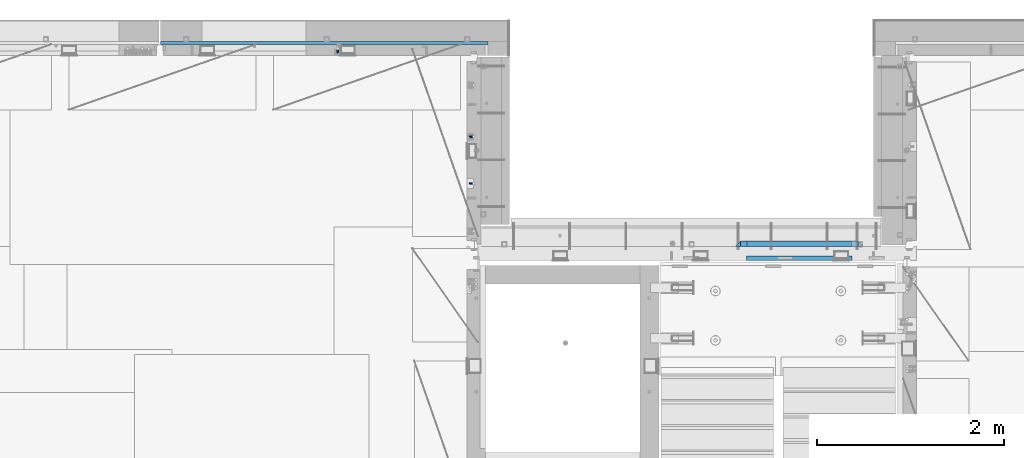
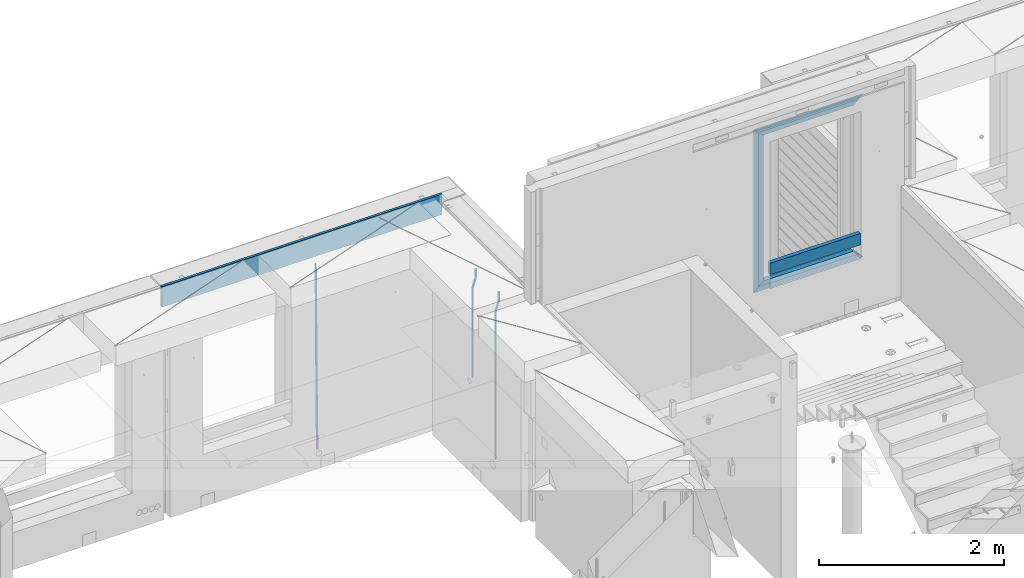
# One storey, part 123 of 349: 11 beams, 3 elements without a shape of their own.
"""IFC2X3 building model written with IfcOpenShell, lengths in millimetres."""

from ifc_helpers import new_model, si_unit, frame, origin_with_axes, place, context, subcontext, project, spatial, faceted_brep, material, type_object, element, aggregate, save


model = new_model("IFC2X3")

# Units and contexts
model_context = context("Model", 3, precision=1e-05, world=origin_with_axes())
body_context = subcontext(model_context, "Body", "Model", "MODEL_VIEW")
ifc_project = project(units=[si_unit("LENGTHUNIT", "METRE", prefix="MILLI"), si_unit("AREAUNIT", "SQUARE_METRE"), si_unit("VOLUMEUNIT", "CUBIC_METRE"), si_unit("MASSUNIT", "GRAM", prefix="KILO"), si_unit("TIMEUNIT", "SECOND"), si_unit("PLANEANGLEUNIT", "RADIAN"), si_unit("SOLIDANGLEUNIT", "STERADIAN"), si_unit("THERMODYNAMICTEMPERATUREUNIT", "DEGREE_CELSIUS"), si_unit("LUMINOUSINTENSITYUNIT", "LUMEN")], contexts=[model_context])

# Site, building, storey
site_placement = place(None, origin_with_axes())
site = spatial("IfcSite", under=ifc_project, at=site_placement, CompositionType="ELEMENT")
building_placement = place(site_placement, origin_with_axes())
building = spatial("IfcBuilding", under=site, at=building_placement, CompositionType="ELEMENT")
storey_placement = place(building_placement, origin_with_axes())
storey = spatial("IfcBuildingStorey", under=building, at=storey_placement, Name="4", CompositionType="ELEMENT", Elevation=0.0)

# Assembly, beam
assembly_1_placement = place(storey_placement, origin_with_axes())
assembly_1 = element("IfcElementAssembly", 1, at=assembly_1_placement, inside=storey, AssemblyPlace="NOTDEFINED", PredefinedType="REINFORCEMENT_UNIT")
ifc_material_1 = material()
beam_type_1 = type_object("IfcBeamType", Name="D20", PredefinedType="NOTDEFINED")
beam_1_placement = place(assembly_1_placement, frame((17685.0, 21755.0073333522, 93407.5), z_axis=(-0.999999913638316, 0.000415599999849952, 0.0), x_axis=(0.0, 0.0, -1.0)))
beam_1 = element("IfcBeam", 2, at=beam_1_placement, type_object=beam_type_1, material=ifc_material_1, Name="JM20", ObjectType="D20", context=body_context, shape_type="Brep", body=[
    faceted_brep([(0.0, -10.0, 0.0), (-4.19531716033816e-08, -7.07106781186667, -7.07106781187031), (113.248091332178, -7.0710684840451, -7.0710678117357), (113.248091314759, -10.0000006713562, -2.51020537689328e-10), (0.0, 0.0, -10.0), (113.248091374131, -6.72178430249915e-07, -9.99999999986903), (4.196772351861e-08, 7.07106781186303, -7.07106781186667), (113.248091416113, 7.07106713968824, -7.07106781173934), (0.0, 10.0, 0.0), (113.248091433488, 9.99999932782521, 1.30967237055302e-10), (4.196772351861e-08, 7.07106781185939, 7.07106781185939), (113.248091416113, 7.0710671396846, 7.071067811994), (0.0, 0.0, 10.0), (113.248091374131, -6.72174792271107e-07, 10.0000000001273), (-4.19531716033816e-08, -7.07106781187031, 7.07106781185939), (113.248091332178, -7.0710684840451, 7.071067811994), (130.699843527167, -7.06993249763036, -4.33745683788584), (128.538066582521, -9.99900540317321, 2.39499413731755), (131.594536475241, 0.00119355250353692, -7.12624594330919), (130.698046432328, 7.07220300913468, -4.33773834422391), (128.535525107087, 10.0009944322555, 2.39459602660281), (126.373748162892, 7.07192152754578, 9.1270470011732), (125.479055214906, 0.000795477419160306, 11.9158361066184), (126.37554525779, -7.07021397921199, 9.12732850753673), (240.336258550378, -7.05529970173666, 30.8729495437874), (238.174481606227, -9.98437260450009, 37.6054005176375), (241.230951498423, 0.0158263482953771, 28.0841604381058), (240.334461455612, 7.0868358050102, 30.8726680369582), (238.171940130502, 10.0156272283348, 37.6050024077231), (236.010163186409, 7.08655432384694, 44.3374533824244), (235.115470238379, 0.0154282738185429, 47.1262424881097), (236.011960281176, -7.05558118289991, 44.3377348892536), (253.461915329972, -7.05444528127919, 32.9289287376414), (253.46191532613, -9.98337746617108, 39.9999965521893), (253.461915339081, 0.0166225284556276, 29.9999965443676), (253.461915348205, 7.08769034247234, 32.9289287273205), (253.461915352003, 10.0166225357716, 39.9999965370152), (253.461915348293, 7.08769035281148, 47.0710643509774), (253.461915339183, 0.0166225430875784, 49.999996544273), (253.46191533003, -7.05444527093641, 47.0710643613093), (1417.49999998364, -7.05444797759628, 32.9289287358552), (1417.49999997689, -9.98338016170965, 39.9999965493844), (1417.49999999996, 0.0166198326005542, 29.9999965436982), (1417.50000001628, 7.08768764613342, 32.9289287278079), (1417.50000002306, 10.0166198382904, 39.9999965380084), (1417.5000000163, 7.08768765417699, 47.0710643515376), (1417.49999999999, 0.0166198439801519, 49.9999965436946), (1417.49999998366, -7.05444796955271, 47.0710643595849)], [[[0, 1, 2, 3]], [[1, 4, 5, 2]], [[4, 6, 7, 5]], [[6, 8, 9, 7]], [[8, 10, 11, 9]], [[10, 12, 13, 11]], [[12, 14, 15, 13]], [[14, 0, 3, 15]], [[14, 12, 10, 8, 6, 4, 1, 0]], [[3, 2, 16, 17]], [[2, 5, 18, 16]], [[5, 7, 19, 18]], [[7, 9, 20, 19]], [[9, 11, 21, 20]], [[11, 13, 22, 21]], [[13, 15, 23, 22]], [[15, 3, 17, 23]], [[17, 16, 24, 25]], [[16, 18, 26, 24]], [[18, 19, 27, 26]], [[19, 20, 28, 27]], [[20, 21, 29, 28]], [[21, 22, 30, 29]], [[22, 23, 31, 30]], [[23, 17, 25, 31]], [[25, 24, 32, 33]], [[24, 26, 34, 32]], [[26, 27, 35, 34]], [[27, 28, 36, 35]], [[28, 29, 37, 36]], [[29, 30, 38, 37]], [[30, 31, 39, 38]], [[31, 25, 33, 39]], [[33, 32, 40, 41]], [[32, 34, 42, 40]], [[34, 35, 43, 42]], [[35, 36, 44, 43]], [[36, 37, 45, 44]], [[37, 38, 46, 45]], [[38, 39, 47, 46]], [[39, 33, 41, 47]], [[42, 43, 44, 45, 46, 47, 41, 40]]]),
])

assembly_2_placement = place(storey_placement, origin_with_axes())
assembly_2 = element("IfcElementAssembly", 3, at=assembly_2_placement, inside=storey, AssemblyPlace="NOTDEFINED", PredefinedType="REINFORCEMENT_UNIT")
beam_2_placement = place(assembly_2_placement, frame((16230.0000000039, 22654.999995444, 90990.0), z_axis=(-0.000205762999925498, 0.999642804629538, -0.0267249099901004), x_axis=(4.30000201928125e-08, 0.0267249099948059, 0.999642825806181)))
beam_2 = element("IfcBeam", 4, at=beam_2_placement, type_object=beam_type_1, material=ifc_material_1, Name="JM20", ObjectType="D20", context=body_context, shape_type="Brep", body=[
    faceted_brep([(0.0, -10.0, 0.0), (-4.19531716033816e-08, -7.07106781186667, -7.07106781187031), (60.4266690400545, -7.0710677960451, -7.07106780570757), (60.4266690441291, -9.99999998418934, 6.15546014159918e-09), (0.0, 0.0, -10.0), (60.426669036824, 1.58106558956206e-08, -9.99999999384454), (4.196772351861e-08, 7.07106781186303, -7.07106781186667), (60.4266690363438, 7.07106782768096, -7.07106780570757), (0.0, 10.0, 0.0), (60.4266690388904, 10.0000000158179, 6.15182216279209e-09), (4.196772351861e-08, 7.07106781185939, 7.07106781185939), (60.4266690429649, 7.07106782768096, 7.07106781802577), (0.0, 0.0, 10.0), (60.4266690461809, 1.58179318532348e-08, 10.0000000061555), (-4.19531716033816e-08, -7.07106781187031, 7.07106781185939), (60.4266690466611, -7.07106779605238, 7.07106781802213), (61.0378400410118, -7.07106779588503, -7.07106780564936), (60.991799419251, -9.99999998403655, 6.21366780251265e-09), (61.0569027789461, 1.5985278878361e-08, -9.99999999378269), (61.0378209396877, 7.07106782784831, -7.07106780564936), (60.9917724058905, 10.0000000159635, 6.21366780251265e-09), (60.9457317841297, 7.07106782781193, 7.0710678180767), (60.9266690461809, 1.59488990902901e-08, 10.0000000062028), (60.9457508854539, -7.07106779591413, 7.0710678180767), (61.6489592143771, -7.07106614513759, -7.06310863441468), (61.5568818710308, -9.9999984576425, 0.00735959856683621), (61.6870830769039, 1.71821739058942e-06, -9.99179257185824), (61.6489210170112, 7.07106947854481, -7.06310888312146), (61.556827851804, 10.0000015422847, 0.00735924683976918), (61.4647505084577, 7.07106922979438, 7.07782747982128), (61.4266266459163, 1.36643211590126e-06, 10.0065114172685), (61.464788705809, -7.07106639389531, 7.07782772852806), (176.543135720174, -7.07075579406956, -5.56673531796696), (176.451058376813, -9.99968810657447, 1.50373291501455), (176.581259582701, 0.000312069292704109, -8.49541925541052), (176.543097522794, 7.07137982961285, -5.56673556667374), (176.451004357587, 10.00031189336, 1.50373256329476), (176.35892701424, 7.07137958085514, 8.57420079627263), (176.320803151699, 0.000311717507429421, 11.5028847337162), (176.358965211621, -7.07075604281999, 8.57420104497578), (177.098753836006, -7.07075429323595, -5.55949898843028), (176.98362511232, -9.99968666800123, 1.510669025065), (177.146421932586, 0.000313595905026887, -8.48805862247536), (177.098706077581, 7.07138133041735, -5.55949936166144), (176.983557571715, 10.0003133318824, 1.51066849724157), (176.868428848029, 7.07138095712435, 8.58083651073321), (176.820760751449, 0.000313067976094317, 11.5093961447819), (176.868476606425, -7.07075466652896, 8.58083688396073), (177.654312950661, -7.07075204110879, -5.54863964998367), (177.516135294456, -9.99968450931192, 1.52107783331303), (177.711524267797, 0.000315886711177882, -8.47701274570863), (177.654255632195, 7.07138358250813, -5.54864021007961), (177.516054233929, 10.0003154905207, 1.5210770412159), (177.377876577739, 7.0713830223176, 8.59079452451624), (177.320665260588, 0.000315094497636892, 11.5191676202448), (177.377933896176, -7.07075260129932, 8.59079508461218), (299.436796249574, -7.07025836271714, -3.1681962331204), (299.298618593355, -9.99919083092027, 3.90152125031091), (299.494007566798, 0.000809565110102994, -6.09656932889993), (299.436738931283, 7.07187726089978, -3.16819679320906), (299.298537533061, 10.0008091689197, 3.90152045822106), (299.160359876842, 7.07187670072017, 10.9712379416487), (299.103148559603, 0.000808772889286047, 13.8996110374392), (299.160417195119, -7.07025892290039, 10.9712385017483), (299.98743051647, -7.07025613056248, -3.15743315966392), (299.971788958996, -9.99918809853989, 3.91467979818117), (299.993912075952, 0.000811591617093654, -6.08679785393178), (299.987423933868, 7.07187949325817, -3.1574327280432), (299.971753863239, 10.0008119014747, 3.91467990454839), (299.95611230444, 7.07187992653053, 10.9867922621015), (299.949630744944, 0.000812204350950196, 13.9161569563694), (299.956118887014, -7.07025569729012, 10.9867918304735), (300.538107039494, -7.07025785017686, -3.16575821840888), (300.644985195438, -9.99919020432935, 3.90450175465594), (300.493854948218, 0.000810030429420294, -6.09435592770024), (300.538151196495, 7.071877773491, -3.16575855385963), (300.645047642858, 10.0008097955724, 3.90450128024895), (300.751925798773, 7.07187744142357, 10.9747612533101), (300.796177890064, 0.000809560813650023, 13.9033589625978), (300.751881641787, -7.07025818224065, 10.9747615887682), (2293.36490490142, -7.07648090940347, -33.2930642912361), (2293.47178305736, -10.0054132635523, -26.2228043181785), (2293.32065281013, -0.00541302880083094, -36.2216620005347), (2293.36494905842, 7.06565471425711, -33.2930646266868), (2293.47184550477, 9.99458673634581, -26.2228047925819), (2293.57872366071, 7.06565438219332, -19.1525448195243), (2293.62297575199, -0.00541349841296324, -16.2239471102366), (2293.57867950371, -7.0764812414709, -19.1525444840736), (2294.0658245362, -7.07648309818615, -33.3036607065333), (2294.05312277409, -10.0054150789219, -26.2315929392535), (2294.10928714235, -0.00541549149056664, -36.2335844756526), (2294.15805078732, 7.06565223761572, -33.3050546393533), (2294.18355038921, 9.99458451388637, -26.2335642579346), (2294.17084862708, 7.06565253314329, -19.1614964906439), (2294.12738602093, -0.00541507354500936, -16.2315727215355), (2294.07862237596, -7.07648280265857, -19.1601025578348), (2294.76670261032, -7.08562269121467, -33.294332712383), (2294.63442802057, -10.0129954178956, -26.2238563411993), (2294.89787471293, -0.0156988342423574, -36.2230891548279), (2294.95110548967, 7.05531064255774, -33.2944998654275), (2294.89521307347, 9.98530428734011, -26.2240927312887), (2294.76293848372, 7.0579315606592, -19.1536163601049), (2294.63176638114, -0.0119922963167483, -16.2248599176673), (2294.57853560438, -7.08300177311321, -19.1534492070678), (2316.52657204497, -7.36937582653991, -33.0047303660212), (2316.39429745522, -10.2967485532172, -25.9342539948302), (2316.65774414754, -0.299451969567599, -35.9334868084661), (2316.7109749243, 6.7715575072325, -33.0048975190657), (2316.65508250811, 9.70155115201487, -25.9344903849269), (2316.52280791836, 6.7741784253376, -18.8640140137468), (2316.39163581574, -0.295745431634714, -15.9352575713092), (2316.33840503903, -7.36675490843481, -18.863846860706), (2317.16202064224, -7.37766220584308, -32.9962731735213), (2317.05438744847, -10.3053562613532, -25.9254688497131), (2317.23607125619, -0.306993473008333, -35.925789846493), (2317.23316144495, 6.76474808850253, -32.9979477328052), (2317.15499573652, 9.6950321815566, -25.9278370341635), (2317.04736254275, 6.7673381260538, -18.8570327103698), (2316.97331192881, -0.303330606784584, -15.9275160373909), (2316.97622174003, -7.37507216829545, -18.8553581510787), (2317.79752306276, -7.37578610372293, -32.9880110666527), (2317.71453320107, -10.3033876998124, -25.9168792378296), (2317.81444760226, -0.305295583297266, -35.918287695793), (2317.75539265381, 6.76628640723357, -32.9911928173897), (2317.65495180529, 9.69652304524061, -25.9213789128698), (2317.5719619436, 6.76892144914746, -18.8502470840467), (2317.55503740412, -0.301569071270933, -15.9199704549137), (2317.61409235255, -7.3731510618054, -18.847065333317), (2417.8183084176, -7.07752398473531, -31.6906369377139), (2417.73531855589, -10.0051255808248, -24.6195051088798), (2417.83523295709, -0.007033464313281, -34.6209135668432), (2417.77617800863, 7.06454852621755, -31.6938186884508), (2417.67573716014, 9.99478516423187, -24.6240047839383), (2417.59274729842, 7.06718356813872, -17.5528729551006), (2417.57582275895, -0.00330695228694822, -14.6225963259749), (2417.6348777074, -7.07488894281778, -17.5496912043673)], [[[0, 1, 2, 3]], [[1, 4, 5, 2]], [[4, 6, 7, 5]], [[6, 8, 9, 7]], [[8, 10, 11, 9]], [[10, 12, 13, 11]], [[12, 14, 15, 13]], [[14, 0, 3, 15]], [[14, 12, 10, 8, 6, 4, 1, 0]], [[3, 2, 16, 17]], [[2, 5, 18, 16]], [[5, 7, 19, 18]], [[7, 9, 20, 19]], [[9, 11, 21, 20]], [[11, 13, 22, 21]], [[13, 15, 23, 22]], [[15, 3, 17, 23]], [[17, 16, 24, 25]], [[16, 18, 26, 24]], [[18, 19, 27, 26]], [[19, 20, 28, 27]], [[20, 21, 29, 28]], [[21, 22, 30, 29]], [[22, 23, 31, 30]], [[23, 17, 25, 31]], [[25, 24, 32, 33]], [[24, 26, 34, 32]], [[26, 27, 35, 34]], [[27, 28, 36, 35]], [[28, 29, 37, 36]], [[29, 30, 38, 37]], [[30, 31, 39, 38]], [[31, 25, 33, 39]], [[33, 32, 40, 41]], [[32, 34, 42, 40]], [[34, 35, 43, 42]], [[35, 36, 44, 43]], [[36, 37, 45, 44]], [[37, 38, 46, 45]], [[38, 39, 47, 46]], [[39, 33, 41, 47]], [[41, 40, 48, 49]], [[40, 42, 50, 48]], [[42, 43, 51, 50]], [[43, 44, 52, 51]], [[44, 45, 53, 52]], [[45, 46, 54, 53]], [[46, 47, 55, 54]], [[47, 41, 49, 55]], [[49, 48, 56, 57]], [[48, 50, 58, 56]], [[50, 51, 59, 58]], [[51, 52, 60, 59]], [[52, 53, 61, 60]], [[53, 54, 62, 61]], [[54, 55, 63, 62]], [[55, 49, 57, 63]], [[57, 56, 64, 65]], [[56, 58, 66, 64]], [[58, 59, 67, 66]], [[59, 60, 68, 67]], [[60, 61, 69, 68]], [[61, 62, 70, 69]], [[62, 63, 71, 70]], [[63, 57, 65, 71]], [[65, 64, 72, 73]], [[64, 66, 74, 72]], [[66, 67, 75, 74]], [[67, 68, 76, 75]], [[68, 69, 77, 76]], [[69, 70, 78, 77]], [[70, 71, 79, 78]], [[71, 65, 73, 79]], [[73, 72, 80, 81]], [[72, 74, 82, 80]], [[74, 75, 83, 82]], [[75, 76, 84, 83]], [[76, 77, 85, 84]], [[77, 78, 86, 85]], [[78, 79, 87, 86]], [[79, 73, 81, 87]], [[81, 80, 88, 89]], [[80, 82, 90, 88]], [[82, 83, 91, 90]], [[83, 84, 92, 91]], [[84, 85, 93, 92]], [[85, 86, 94, 93]], [[86, 87, 95, 94]], [[87, 81, 89, 95]], [[89, 88, 96, 97]], [[88, 90, 98, 96]], [[90, 91, 99, 98]], [[91, 92, 100, 99]], [[92, 93, 101, 100]], [[93, 94, 102, 101]], [[94, 95, 103, 102]], [[95, 89, 97, 103]], [[97, 96, 104, 105]], [[96, 98, 106, 104]], [[98, 99, 107, 106]], [[99, 100, 108, 107]], [[100, 101, 109, 108]], [[101, 102, 110, 109]], [[102, 103, 111, 110]], [[103, 97, 105, 111]], [[105, 104, 112, 113]], [[104, 106, 114, 112]], [[106, 107, 115, 114]], [[107, 108, 116, 115]], [[108, 109, 117, 116]], [[109, 110, 118, 117]], [[110, 111, 119, 118]], [[111, 105, 113, 119]], [[113, 112, 120, 121]], [[112, 114, 122, 120]], [[114, 115, 123, 122]], [[115, 116, 124, 123]], [[116, 117, 125, 124]], [[117, 118, 126, 125]], [[118, 119, 127, 126]], [[119, 113, 121, 127]], [[121, 120, 128, 129]], [[120, 122, 130, 128]], [[122, 123, 131, 130]], [[123, 124, 132, 131]], [[124, 125, 133, 132]], [[125, 126, 134, 133]], [[126, 127, 135, 134]], [[127, 121, 129, 135]], [[130, 131, 132, 133, 134, 135, 129, 128]]]),
])

# Beam
beam_type_2 = type_object("IfcBeamType", Name="D25", PredefinedType="NOTDEFINED")
beam_3_placement = place(assembly_1_placement, frame((17685.0, 21255.0073333522, 93407.5), z_axis=(-0.999999913638316, 0.000415599999849952, 0.0), x_axis=(0.0, 0.0, -1.0)))
beam_3 = element("IfcBeam", 5, at=beam_3_placement, type_object=beam_type_2, material=ifc_material_1, Name="JM25", ObjectType="D25", context=body_context, shape_type="Brep", body=[
    faceted_brep([(-7.41420080885291e-08, -12.5, -3.63797880709171e-12), (-6.42030499875546e-08, -10.8253175473074, -6.25000000000364), (113.248091310059, -10.8253182190492, -6.25000000001091), (113.248091299931, -12.5000006708469, -2.80124368146062e-10), (-3.70782800018787e-08, -6.25000000000364, -10.8253175473074), (113.248091337184, -6.25000067174187, -10.8253175473183), (-1.45519152283669e-11, -3.63797880709171e-12, -12.5), (113.248091374247, -6.71741872793064e-07, -12.5000000000109), (3.70637280866504e-08, 6.25, -10.8253175473074), (113.248091411326, 6.24999932825813, -10.8253175473183), (6.42030499875546e-08, 10.8253175473001, -6.25000000000364), (113.248091438465, 10.8253168755618, -6.25000000001091), (7.41420080885291e-08, 12.4999999999927, 0.0), (113.248091448404, 12.4999993282545, -1.09139364212751e-11), (6.42176019027829e-08, 10.8253175473001, 6.24999999999636), (113.24809143848, 10.8253168755618, 6.24999999998545), (3.70928319171071e-08, 6.24999999999636, 10.8253175473037), (113.248091411355, 6.24999932825449, 10.8253175472928), (1.45519152283669e-11, -3.63797880709171e-12, 12.4999999999964), (113.248091374277, -6.71741872793064e-07, 12.4999999999854), (-3.7049176171422e-08, -6.25000000000364, 10.8253175473001), (113.248091337213, -6.25000067174187, 10.8253175472928), (-6.41884980723262e-08, -10.8253175473074, 6.25), (113.248091310074, -10.8253182190492, 6.24999999998909), (130.449259230882, -10.8241986432586, -3.55564009493173), (128.538384125903, -12.4990054706068, 2.39504387892885), (131.847691315706, -6.24879007587151, -7.91190976778307), (132.358971633032, 0.00124320192480809, -9.50650619965018), (131.846103034666, 6.25120982069348, -7.91215856435883), (130.446508247391, 10.826436272193, -3.55607102324211), (128.535207564215, 12.5009943235709, 2.39454628487874), (126.624332459658, 10.8261874972886, 8.34523025788076), (125.225900374833, 6.25077892990521, 12.7014999307248), (124.714620057581, 0.000745652105251793, 14.2960963626065), (125.227488655888, -6.24922096664886, 12.7017487273151), (126.62708344312, -10.8244474181665, 8.3456611861875), (240.085674248156, -10.8095671496994, 31.6547662857156), (238.174799143511, -12.4843739739517, 37.6054502584157), (241.484106332937, -6.23415858247972, 27.2984966126423), (241.995386650233, 0.0158746952838555, 25.703900180506), (241.482518051911, 6.26584131414347, 27.2982478155536), (240.082923264708, 10.8410677658503, 31.6543353565175), (238.171622581605, 12.5156258174902, 37.6049526646493), (236.260747477107, 10.8408189914335, 43.5556366377568), (234.862315392325, 6.26541042421377, 47.9119063108337), (234.351035075029, 0.0153771464501915, 49.5065027429664), (234.863903673351, -6.23458947240579, 47.9121551079224), (236.263498460554, -10.8098159241163, 43.5560675669512), (253.461915305525, -10.8086965039183, 33.7499965486895), (253.461915300941, -12.4833789551158, 39.9999965501447), (253.461915317355, -6.23337895905206, 29.1746789989811), (253.461915333464, 0.0166210400311684, 27.4999965429452), (253.461915349588, 6.26662104088609, 29.1746789923018), (253.461915361389, 10.8419385905909, 33.7499965371353), (253.461915365653, 12.5166210465904, 39.9999965362076), (253.461915361288, 10.8419385972084, 46.2499965370662), (253.461915349428, 6.26662105234573, 50.8253140867819), (253.461915333304, 0.0166210532552213, 52.4999965428069), (253.461915317152, -6.23337894759607, 50.8253140934612), (253.461915305408, -10.8086964973008, 46.2499965486277), (2197.49999997206, -10.8087015173915, 33.749996548926), (2197.49999996777, -12.4833839668026, 39.9999965498064), (2197.49999998385, -6.23338397248881, 29.1746789992176), (2197.49999999997, 0.0166160266307998, 27.4999965432398), (2197.50000001608, 6.26661602751119, 29.1746789926474), (2197.5000000279, 10.8419335772196, 33.74999653755), (2197.5000000322, 12.5166160331937, 39.9999965366696), (2197.50000002791, 10.8419335837862, 46.2499965375537), (2197.50000001611, 6.26661603888351, 50.8253140872584), (2197.5, 0.0166160397602653, 52.4999965432398), (2197.49999998388, -6.23338396111649, 50.825314093825), (2197.49999997209, -10.8087015108249, 46.2499965489224)], [[[0, 1, 2, 3]], [[1, 4, 5, 2]], [[4, 6, 7, 5]], [[6, 8, 9, 7]], [[8, 10, 11, 9]], [[10, 12, 13, 11]], [[12, 14, 15, 13]], [[14, 16, 17, 15]], [[16, 18, 19, 17]], [[18, 20, 21, 19]], [[20, 22, 23, 21]], [[22, 0, 3, 23]], [[22, 20, 18, 16, 14, 12, 10, 8, 6, 4, 1, 0]], [[3, 2, 24, 25]], [[2, 5, 26, 24]], [[5, 7, 27, 26]], [[7, 9, 28, 27]], [[9, 11, 29, 28]], [[11, 13, 30, 29]], [[13, 15, 31, 30]], [[15, 17, 32, 31]], [[17, 19, 33, 32]], [[19, 21, 34, 33]], [[21, 23, 35, 34]], [[23, 3, 25, 35]], [[25, 24, 36, 37]], [[24, 26, 38, 36]], [[26, 27, 39, 38]], [[27, 28, 40, 39]], [[28, 29, 41, 40]], [[29, 30, 42, 41]], [[30, 31, 43, 42]], [[31, 32, 44, 43]], [[32, 33, 45, 44]], [[33, 34, 46, 45]], [[34, 35, 47, 46]], [[35, 25, 37, 47]], [[37, 36, 48, 49]], [[36, 38, 50, 48]], [[38, 39, 51, 50]], [[39, 40, 52, 51]], [[40, 41, 53, 52]], [[41, 42, 54, 53]], [[42, 43, 55, 54]], [[43, 44, 56, 55]], [[44, 45, 57, 56]], [[45, 46, 58, 57]], [[46, 47, 59, 58]], [[47, 37, 49, 59]], [[49, 48, 60, 61]], [[48, 50, 62, 60]], [[50, 51, 63, 62]], [[51, 52, 64, 63]], [[52, 53, 65, 64]], [[53, 54, 66, 65]], [[54, 55, 67, 66]], [[55, 56, 68, 67]], [[56, 57, 69, 68]], [[57, 58, 70, 69]], [[58, 59, 71, 70]], [[59, 49, 61, 71]], [[62, 63, 64, 65, 66, 67, 68, 69, 70, 71, 61, 60]]]),
])

aggregate(assembly_1, [beam_3, beam_1])

# Assembly, beams
assembly_3_placement = place(storey_placement, origin_with_axes())
assembly_3 = element("IfcElementAssembly", 6, at=assembly_3_placement, inside=storey, AssemblyPlace="NOTDEFINED", PredefinedType="REINFORCEMENT_UNIT")
ifc_material_2 = material(Name="TIMBER/T24")
beam_type_3 = type_object("IfcBeamType", PredefinedType="NOTDEFINED")
beam_4_placement = place(assembly_3_placement, frame((21724.9984049797, 20455.0, 93185.0), z_axis=(0.0, 0.0, 1.0), x_axis=(-1.0, 3.00000001838171e-08, 0.0)))
beam_4 = element("IfcBeam", 7, at=beam_4_placement, type_object=beam_type_3, material=ifc_material_2, context=body_context, shape_type="Brep", body=[
    faceted_brep([(-3.63797880709171e-12, 24.9999999999964, -75.0), (-3.63797880709171e-12, 24.9999999999964, 75.0), (1130.0, 25.0, 75.0), (1130.0, 25.0, -75.0), (0.0, -25.0000000000073, 75.0), (1130.0, -25.0, 75.0), (0.0, -25.0000000000073, -75.0), (1130.0, -25.0, -75.0)], [[[0, 1, 2, 3]], [[1, 4, 5, 2]], [[4, 6, 7, 5]], [[6, 0, 3, 7]], [[5, 7, 3, 2]], [[6, 4, 1, 0]]]),
])
ifc_material_3 = material(Name="CONCRETE/C25/30")
beam_type_4 = type_object("IfcBeamType", PredefinedType="NOTDEFINED")
beam_5_placement = place(assembly_3_placement, frame((21844.9984049797, 20610.0000000447, 94945.0), z_axis=(0.0, 0.0, -1.0), x_axis=(-1.0, 3.00000001838171e-08, 0.0)))
beam_5 = element("IfcBeam", 8, at=beam_5_placement, type_object=beam_type_4, material=ifc_material_3, context=body_context, shape_type="Brep", body=[
    faceted_brep([(1310.0, -30.0, 30.0), (60.0000000000073, -30.0, 30.0), (0.0, -30.0, -30.0), (1370.0, -30.0, -30.0), (1310.0, 30.0, 30.0), (60.0000000000073, 30.0, 30.0)], [[[0, 1, 2, 3]], [[0, 3, 4]], [[1, 0, 4, 5]], [[5, 2, 1]], [[4, 3, 2, 5]]]),
])
beam_6_placement = place(assembly_3_placement, frame((21784.9984049797, 20609.9999988829, 94885.0), z_axis=(0.0, 0.0, -1.0), x_axis=(-1.0, 3.00000001838171e-08, 0.0)))
beam_6 = element("IfcBeam", 9, at=beam_6_placement, type_object=beam_type_4, material=ifc_material_3, context=body_context, shape_type="Brep", body=[
    faceted_brep([(0.0, -30.0, -30.0), (64.0540540540533, -30.0, 24.9034748914419), (65.6756756756768, 30.0, 26.293436281092), (0.0, 30.0, -30.0), (64.0540540540533, -30.0, 24.0540540540533), (65.6756756756768, 30.0, 25.6756756756804), (1185.94594588314, -29.9999988381387, 24.0540541168593), (1184.32432432432, 29.9999988381387, 25.6756756756804), (1184.32432432432, 29.9999988381387, 26.2934362810629), (1250.0, 29.9999988381387, -30.0), (1250.0, -29.9999988381387, -30.0), (1185.94594588314, -29.9999988381387, 24.9034749452549)], [[[0, 1, 2, 3]], [[4, 5, 2, 1]], [[6, 7, 5, 4]], [[3, 2, 5, 7, 8, 9]], [[0, 3, 9, 10]], [[6, 4, 1, 0, 10, 11]], [[7, 6, 11, 8]], [[10, 9, 8, 11]]]),
])
beam_7_placement = place(assembly_3_placement, frame((20504.9984049797, 20610.0000000447, 94975.0), z_axis=(1.0, 0.0, 0.0), x_axis=(0.0, 0.0, -1.0)))
beam_7 = element("IfcBeam", 10, at=beam_7_placement, type_object=beam_type_4, material=ifc_material_3, context=body_context, shape_type="Brep", body=[
    faceted_brep([(60.0000000000073, 30.0, 30.0), (0.0, -30.0, -30.0), (60.0000000000073, -30.0, 30.0), (2095.00000000001, -30.0, 30.0), (2155.0, -30.0, -30.0), (2095.00000000001, 30.0, 30.0)], [[[0, 1, 2]], [[3, 2, 1, 4]], [[3, 4, 5]], [[2, 3, 5, 0]], [[4, 1, 0, 5]]]),
])
beam_8_placement = place(assembly_3_placement, frame((20534.9984049797, 20609.9999988829, 92910.0), z_axis=(0.0, 0.0, 1.0), x_axis=(1.0, 0.0, 0.0)))
beam_8 = element("IfcBeam", 11, at=beam_8_placement, type_object=beam_type_4, material=ifc_material_3, context=body_context, shape_type="Brep", body=[
    faceted_brep([(1185.94594588314, -29.9999988381387, 24.0540541168593), (1184.32432432432, 29.9999988381387, 25.6756756756804), (65.6756756756768, 30.0, 25.6756756756804), (64.0540540540533, -30.0, 24.0540540540533), (65.6756756756768, 30.0, 26.293436281092), (64.0540540540533, -30.0, 24.9034748914419), (0.0, -30.0, -30.0), (0.0, 30.0, -30.0), (1250.0, 29.9999988381387, -30.0), (1250.0, -29.9999988381387, -30.0), (1185.94594588314, -29.9999988381387, 24.9034749452549), (1184.32432432432, 29.9999988381387, 26.2934362810629)], [[[0, 1, 2, 3]], [[3, 2, 4, 5]], [[6, 5, 4, 7]], [[6, 7, 8, 9]], [[0, 3, 5, 6, 9, 10]], [[1, 0, 10, 11]], [[7, 4, 2, 1, 11, 8]], [[9, 8, 11, 10]]]),
])
beam_9_placement = place(assembly_3_placement, frame((20474.9984049797, 20610.0000000447, 92850.0), z_axis=(0.0, 0.0, 1.0), x_axis=(1.0, 0.0, 0.0)))
beam_9 = element("IfcBeam", 12, at=beam_9_placement, type_object=beam_type_4, material=ifc_material_3, context=body_context, shape_type="Brep", body=[
    faceted_brep([(60.0000000000073, 30.0, 30.0), (0.0, -30.0, -30.0), (60.0000000000073, -30.0, 30.0), (1310.0, -30.0, 30.0), (1370.0, -30.0, -30.0), (1310.0, 30.0, 30.0)], [[[0, 1, 2]], [[3, 2, 1, 4]], [[2, 3, 5, 0]], [[5, 4, 1, 0]], [[3, 4, 5]]]),
])
beam_type_5 = type_object("IfcBeamType", PredefinedType="NOTDEFINED")
beam_10_placement = place(assembly_3_placement, frame((20569.9984049797, 20609.9999988829, 94915.0), z_axis=(1.0, 0.0, 0.0), x_axis=(0.0, 0.0, -1.0)))
beam_10 = element("IfcBeam", 13, at=beam_10_placement, type_object=beam_type_5, material=ifc_material_3, context=body_context, shape_type="Brep", body=[
    faceted_brep([(2035.0, -29.9999988381387, -35.0), (2035.0, 29.9999988381387, -35.0), (1978.70656371892, 29.9999988381387, 30.6756756756731), (1980.09652505475, -29.9999988381387, 29.0540541168557), (56.2934362811066, 30.0, 30.6756756756768), (54.9034748914273, -30.0, 29.0540540540533), (0.0, -30.0, -35.0), (0.0, 30.0, -35.0)], [[[0, 1, 2, 3]], [[3, 2, 4, 5]], [[0, 3, 5, 6]], [[1, 0, 6, 7]], [[2, 1, 7, 4]], [[6, 5, 4, 7]]]),
])
aggregate(assembly_3, [beam_5, beam_6, beam_7, beam_10, beam_8, beam_9, beam_4])

# Beam
beam_type_6 = type_object("IfcBeamType", Name="270X30", PredefinedType="NOTDEFINED")
beam_11_placement = place(assembly_2_placement, frame((17835.0, 22755.0, 93605.0), z_axis=(0.0, 0.0, 1.0), x_axis=(-1.0, 3.00000001838171e-08, 0.0)))
beam_11 = element("IfcBeam", 14, at=beam_11_placement, type_object=beam_type_6, material=ifc_material_3, ObjectType="270X30", context=body_context, shape_type="Brep", body=[
    faceted_brep([(0.0, 15.0, -135.0), (0.0, 15.0, 135.0), (3495.00000000002, 15.0, 135.0), (3495.00000000002, 15.0, -135.0), (0.0, -15.0, 135.0), (3495.00000000002, -15.0, 135.0), (0.0, -15.0, -135.0), (3495.00000000002, -15.0, -135.0)], [[[0, 1, 2, 3]], [[1, 4, 5, 2]], [[4, 6, 7, 5]], [[6, 0, 3, 7]], [[5, 7, 3, 2]], [[6, 4, 1, 0]]]),
])

aggregate(assembly_2, [beam_2, beam_11])

save(model, "model.ifc")
